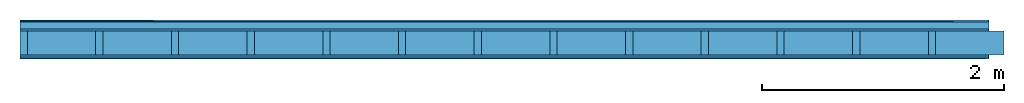
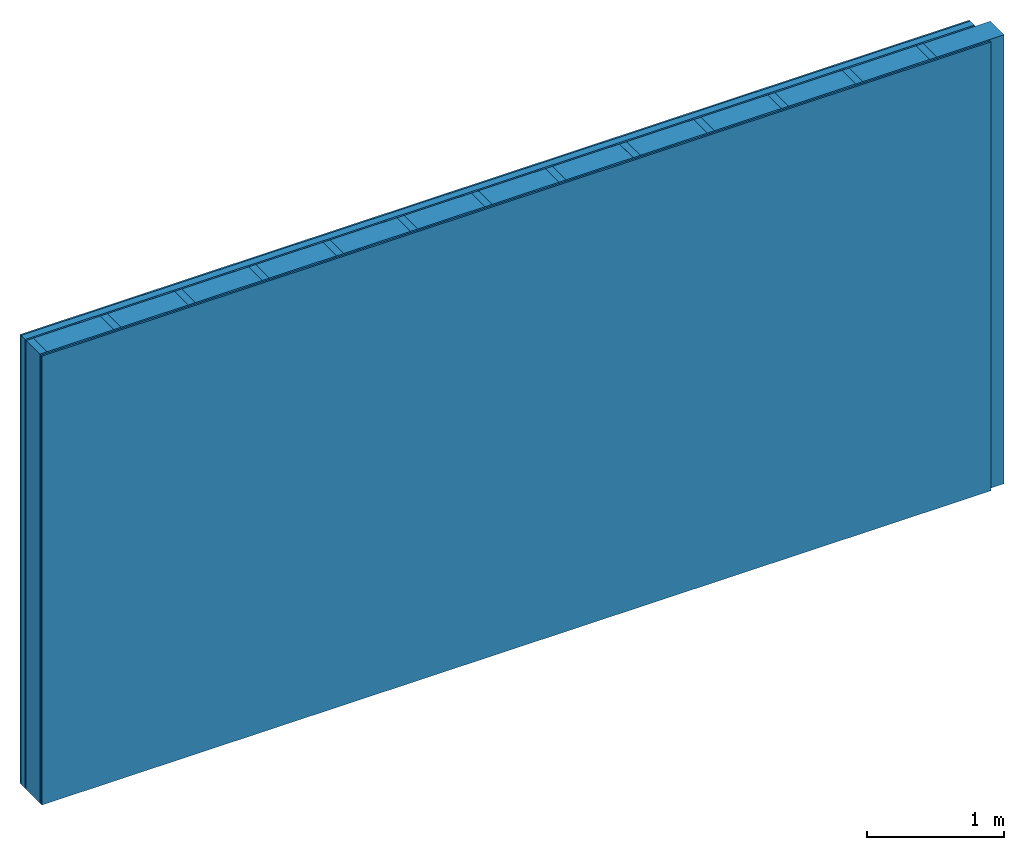
# One storey: 5 plates, 2 members, 1 element without a shape of its own.
"""IFC4 building model written with IfcOpenShell, lengths in metres."""

from ifc_helpers import new_model, si_unit, derived_unit, direction, frame, frame_2d, origin, origin_with_axes, place, context, project, spatial, rectangle, extrude, material, layer, layer_set, type_object, element, aggregate, save


model = new_model("IFC4")

# Units and contexts
plan_context = context("Plan", 3, precision=1e-05, world=origin(), true_north=direction((0.0, 1.0)))
model_context = context("Model", 3, precision=1e-05, world=origin(), true_north=direction((0.0, 1.0)))
ifc_project = project(units=[si_unit("LENGTHUNIT", "METRE"), derived_unit("SOUNDPRESSUREUNIT", [(si_unit("PRESSUREUNIT", "PASCAL", prefix="MICRO"), 0)]), si_unit("ENERGYUNIT", "JOULE", prefix="MEGA"), si_unit("MASSUNIT", "GRAM", prefix="KILO"), derived_unit("THERMALTRANSMITTANCEUNIT", [(si_unit("POWERUNIT", "WATT"), 1), (si_unit("AREAUNIT", "SQUARE_METRE"), -1), (si_unit("THERMODYNAMICTEMPERATUREUNIT", "KELVIN"), -1)]), derived_unit("AREADENSITYUNIT", [(si_unit("MASSUNIT", "GRAM", prefix="KILO"), 1), (si_unit("AREAUNIT", "SQUARE_METRE"), -1)]), derived_unit("USERDEFINED", [(si_unit("ENERGYUNIT", "JOULE", prefix="MEGA"), 1), (si_unit("AREAUNIT", "SQUARE_METRE"), -1)])], contexts=[plan_context, model_context])

# Site, building, storey
site = spatial("IfcSite", under=ifc_project)
building_placement = place(None, origin())
building = spatial("IfcBuilding", under=site, at=building_placement)
storey_placement = place(building_placement, origin())
storey = spatial("IfcBuildingStorey", under=building, at=storey_placement)

# Wall, members, plates
ifc_material_1 = material(Category="04.011")
ifc_layer_1 = layer(ifc_material_1, 0.015, Name="Surface 1")
ifc_material_2 = material(Category="10.008")
ifc_layer_2 = layer(ifc_material_2, 0.06, Name="outside 2nd layer")
ifc_material_3 = material(Category="03.007")
ifc_layer_3 = layer(ifc_material_3, 0.015, Name="outside 1st layer")
ifc_material_4 = material(Name="of the art")
ifc_layer_4 = layer(ifc_material_4, 0.0, Name="Bond")
ifc_layer_5 = layer(None, 0.2, Name="Support")
ifc_layer_6 = layer(ifc_material_4, 0.0, Name="Bond")
ifc_layer_7 = layer(ifc_material_3, 0.015, Name="1st layer")
ifc_layer_8 = layer(ifc_material_3, 0.015, Name="2nd layer")
ifc_material_5 = material(Name="Glued joints")
ifc_layer_9 = layer(ifc_material_5, 0.0, Name="Surface")
ifc_layer_set = layer_set([ifc_layer_1, ifc_layer_2, ifc_layer_3, ifc_layer_4, ifc_layer_5, ifc_layer_6, ifc_layer_7, ifc_layer_8, ifc_layer_9])
wall_type = type_object("IfcWallType", Name="D0461", PredefinedType="NOTDEFINED", material=ifc_layer_set)
wall_placement = place(None, frame((0.0, 0.0, 0.0), z_axis=(0.0, -1.0, 0.0), x_axis=(1.0, 0.0, 0.0)))
wall = element("IfcWall", 1, at=wall_placement, inside=storey, type_object=wall_type, material=ifc_layer_set, Name="Wall #1")
ifc_material_6 = material()
member_1_placement = place(wall_placement, origin())
member_1 = element("IfcMember", 2, at=member_1_placement, material=ifc_material_6, Name="Support", context=plan_context, shape_type="SweptSolid", body=[
    extrude(rectangle(XDim=0.06, YDim=0.2, at=frame_2d((0.03, 0.1), x_axis=(1.0, 0.0))), frame((0.0, 4.0, 0.09), z_axis=(0.0, -1.0, 0.0), x_axis=(1.0, 0.0, 0.0)), (0.0, 0.0, 1.0), 4.0),
    extrude(rectangle(XDim=0.06, YDim=0.2, at=frame_2d((0.03, 0.1), x_axis=(1.0, 0.0))), frame((0.625, 4.0, 0.09), z_axis=(0.0, -1.0, 0.0), x_axis=(1.0, 0.0, 0.0)), (0.0, 0.0, 1.0), 4.0),
    extrude(rectangle(XDim=0.06, YDim=0.2, at=frame_2d((0.03, 0.1), x_axis=(1.0, 0.0))), frame((1.25, 4.0, 0.09), z_axis=(0.0, -1.0, 0.0), x_axis=(1.0, 0.0, 0.0)), (0.0, 0.0, 1.0), 4.0),
    extrude(rectangle(XDim=0.06, YDim=0.2, at=frame_2d((0.03, 0.1), x_axis=(1.0, 0.0))), frame((1.875, 4.0, 0.09), z_axis=(0.0, -1.0, 0.0), x_axis=(1.0, 0.0, 0.0)), (0.0, 0.0, 1.0), 4.0),
    extrude(rectangle(XDim=0.06, YDim=0.2, at=frame_2d((0.03, 0.1), x_axis=(1.0, 0.0))), frame((2.5, 4.0, 0.09), z_axis=(0.0, -1.0, 0.0), x_axis=(1.0, 0.0, 0.0)), (0.0, 0.0, 1.0), 4.0),
    extrude(rectangle(XDim=0.06, YDim=0.2, at=frame_2d((0.03, 0.1), x_axis=(1.0, 0.0))), frame((3.125, 4.0, 0.09), z_axis=(0.0, -1.0, 0.0), x_axis=(1.0, 0.0, 0.0)), (0.0, 0.0, 1.0), 4.0),
    extrude(rectangle(XDim=0.06, YDim=0.2, at=frame_2d((0.03, 0.1), x_axis=(1.0, 0.0))), frame((3.75, 4.0, 0.09), z_axis=(0.0, -1.0, 0.0), x_axis=(1.0, 0.0, 0.0)), (0.0, 0.0, 1.0), 4.0),
    extrude(rectangle(XDim=0.06, YDim=0.2, at=frame_2d((0.03, 0.1), x_axis=(1.0, 0.0))), frame((4.375, 4.0, 0.09), z_axis=(0.0, -1.0, 0.0), x_axis=(1.0, 0.0, 0.0)), (0.0, 0.0, 1.0), 4.0),
    extrude(rectangle(XDim=0.06, YDim=0.2, at=frame_2d((0.03, 0.1), x_axis=(1.0, 0.0))), frame((5.0, 4.0, 0.09), z_axis=(0.0, -1.0, 0.0), x_axis=(1.0, 0.0, 0.0)), (0.0, 0.0, 1.0), 4.0),
    extrude(rectangle(XDim=0.06, YDim=0.2, at=frame_2d((0.03, 0.1), x_axis=(1.0, 0.0))), frame((5.625, 4.0, 0.09), z_axis=(0.0, -1.0, 0.0), x_axis=(1.0, 0.0, 0.0)), (0.0, 0.0, 1.0), 4.0),
    extrude(rectangle(XDim=0.06, YDim=0.2, at=frame_2d((0.03, 0.1), x_axis=(1.0, 0.0))), frame((6.25, 4.0, 0.09), z_axis=(0.0, -1.0, 0.0), x_axis=(1.0, 0.0, 0.0)), (0.0, 0.0, 1.0), 4.0),
    extrude(rectangle(XDim=0.06, YDim=0.2, at=frame_2d((0.03, 0.1), x_axis=(1.0, 0.0))), frame((6.875, 4.0, 0.09), z_axis=(0.0, -1.0, 0.0), x_axis=(1.0, 0.0, 0.0)), (0.0, 0.0, 1.0), 4.0),
    extrude(rectangle(XDim=0.06, YDim=0.2, at=frame_2d((0.03, 0.1), x_axis=(1.0, 0.0))), frame((7.5, 4.0, 0.09), z_axis=(0.0, -1.0, 0.0), x_axis=(1.0, 0.0, 0.0)), (0.0, 0.0, 1.0), 4.0),
])
ifc_material_7 = material()
member_2_placement = place(wall_placement, origin())
member_2 = element("IfcMember", 3, at=member_2_placement, material=ifc_material_7, Name="Cavity", context=plan_context, shape_type="SweptSolid", body=[
    extrude(rectangle(XDim=0.565, YDim=0.2, at=frame_2d((0.2825, 0.1), x_axis=(1.0, 0.0))), frame((0.06, 4.0, 0.09), z_axis=(0.0, -1.0, 0.0), x_axis=(1.0, 0.0, 0.0)), (0.0, 0.0, 1.0), 4.0),
    extrude(rectangle(XDim=0.565, YDim=0.2, at=frame_2d((0.2825, 0.1), x_axis=(1.0, 0.0))), frame((0.685, 4.0, 0.09), z_axis=(0.0, -1.0, 0.0), x_axis=(1.0, 0.0, 0.0)), (0.0, 0.0, 1.0), 4.0),
    extrude(rectangle(XDim=0.565, YDim=0.2, at=frame_2d((0.2825, 0.1), x_axis=(1.0, 0.0))), frame((1.31, 4.0, 0.09), z_axis=(0.0, -1.0, 0.0), x_axis=(1.0, 0.0, 0.0)), (0.0, 0.0, 1.0), 4.0),
    extrude(rectangle(XDim=0.565, YDim=0.2, at=frame_2d((0.2825, 0.1), x_axis=(1.0, 0.0))), frame((1.935, 4.0, 0.09), z_axis=(0.0, -1.0, 0.0), x_axis=(1.0, 0.0, 0.0)), (0.0, 0.0, 1.0), 4.0),
    extrude(rectangle(XDim=0.565, YDim=0.2, at=frame_2d((0.2825, 0.1), x_axis=(1.0, 0.0))), frame((2.56, 4.0, 0.09), z_axis=(0.0, -1.0, 0.0), x_axis=(1.0, 0.0, 0.0)), (0.0, 0.0, 1.0), 4.0),
    extrude(rectangle(XDim=0.565, YDim=0.2, at=frame_2d((0.2825, 0.1), x_axis=(1.0, 0.0))), frame((3.185, 4.0, 0.09), z_axis=(0.0, -1.0, 0.0), x_axis=(1.0, 0.0, 0.0)), (0.0, 0.0, 1.0), 4.0),
    extrude(rectangle(XDim=0.565, YDim=0.2, at=frame_2d((0.2825, 0.1), x_axis=(1.0, 0.0))), frame((3.81, 4.0, 0.09), z_axis=(0.0, -1.0, 0.0), x_axis=(1.0, 0.0, 0.0)), (0.0, 0.0, 1.0), 4.0),
    extrude(rectangle(XDim=0.565, YDim=0.2, at=frame_2d((0.2825, 0.1), x_axis=(1.0, 0.0))), frame((4.435, 4.0, 0.09), z_axis=(0.0, -1.0, 0.0), x_axis=(1.0, 0.0, 0.0)), (0.0, 0.0, 1.0), 4.0),
    extrude(rectangle(XDim=0.565, YDim=0.2, at=frame_2d((0.2825, 0.1), x_axis=(1.0, 0.0))), frame((5.06, 4.0, 0.09), z_axis=(0.0, -1.0, 0.0), x_axis=(1.0, 0.0, 0.0)), (0.0, 0.0, 1.0), 4.0),
    extrude(rectangle(XDim=0.565, YDim=0.2, at=frame_2d((0.2825, 0.1), x_axis=(1.0, 0.0))), frame((5.685, 4.0, 0.09), z_axis=(0.0, -1.0, 0.0), x_axis=(1.0, 0.0, 0.0)), (0.0, 0.0, 1.0), 4.0),
    extrude(rectangle(XDim=0.565, YDim=0.2, at=frame_2d((0.2825, 0.1), x_axis=(1.0, 0.0))), frame((6.31, 4.0, 0.09), z_axis=(0.0, -1.0, 0.0), x_axis=(1.0, 0.0, 0.0)), (0.0, 0.0, 1.0), 4.0),
    extrude(rectangle(XDim=0.565, YDim=0.2, at=frame_2d((0.2825, 0.1), x_axis=(1.0, 0.0))), frame((6.935, 4.0, 0.09), z_axis=(0.0, -1.0, 0.0), x_axis=(1.0, 0.0, 0.0)), (0.0, 0.0, 1.0), 4.0),
    extrude(rectangle(XDim=0.565, YDim=0.2, at=frame_2d((0.2825, 0.1), x_axis=(1.0, 0.0))), frame((7.56, 4.0, 0.09), z_axis=(0.0, -1.0, 0.0), x_axis=(1.0, 0.0, 0.0)), (0.0, 0.0, 1.0), 4.0),
])
plate_1_placement = place(wall_placement, origin())
plate_1 = element("IfcPlate", 4, at=plate_1_placement, material=ifc_material_1, Name="Surface 1", context=plan_context, shape_type="SweptSolid", body=[
    extrude(rectangle(XDim=8.0, YDim=4.0, at=frame_2d((4.0, 2.0), x_axis=(1.0, 0.0))), origin_with_axes(), (0.0, 0.0, 1.0), 0.015),
])
plate_2_placement = place(wall_placement, origin())
plate_2 = element("IfcPlate", 5, at=plate_2_placement, material=ifc_material_2, Name="outside 2nd layer", context=plan_context, shape_type="SweptSolid", body=[
    extrude(rectangle(XDim=8.0, YDim=4.0, at=frame_2d((4.0, 2.0), x_axis=(1.0, 0.0))), frame((0.0, 0.0, 0.015), z_axis=(0.0, 0.0, 1.0), x_axis=(1.0, 0.0, 0.0)), (0.0, 0.0, 1.0), 0.06),
])
plate_3_placement = place(wall_placement, origin())
plate_3 = element("IfcPlate", 6, at=plate_3_placement, material=ifc_material_3, Name="outside 1st layer", context=plan_context, shape_type="SweptSolid", body=[
    extrude(rectangle(XDim=8.0, YDim=4.0, at=frame_2d((4.0, 2.0), x_axis=(1.0, 0.0))), frame((0.0, 0.0, 0.075), z_axis=(0.0, 0.0, 1.0), x_axis=(1.0, 0.0, 0.0)), (0.0, 0.0, 1.0), 0.015),
])
plate_4_placement = place(wall_placement, origin())
plate_4 = element("IfcPlate", 7, at=plate_4_placement, material=ifc_material_3, Name="1st layer", context=plan_context, shape_type="SweptSolid", body=[
    extrude(rectangle(XDim=8.0, YDim=4.0, at=frame_2d((4.0, 2.0), x_axis=(1.0, 0.0))), frame((0.0, 0.0, 0.29), z_axis=(0.0, 0.0, 1.0), x_axis=(1.0, 0.0, 0.0)), (0.0, 0.0, 1.0), 0.015),
])
plate_5_placement = place(wall_placement, origin())
plate_5 = element("IfcPlate", 8, at=plate_5_placement, material=ifc_material_3, Name="2nd layer", context=plan_context, shape_type="SweptSolid", body=[
    extrude(rectangle(XDim=8.0, YDim=4.0, at=frame_2d((4.0, 2.0), x_axis=(1.0, 0.0))), frame((0.0, 0.0, 0.305), z_axis=(0.0, 0.0, 1.0), x_axis=(1.0, 0.0, 0.0)), (0.0, 0.0, 1.0), 0.015),
])
aggregate(wall, [plate_1, plate_2, plate_3, member_1, member_2, plate_4, plate_5])

save(model, "model.ifc")
